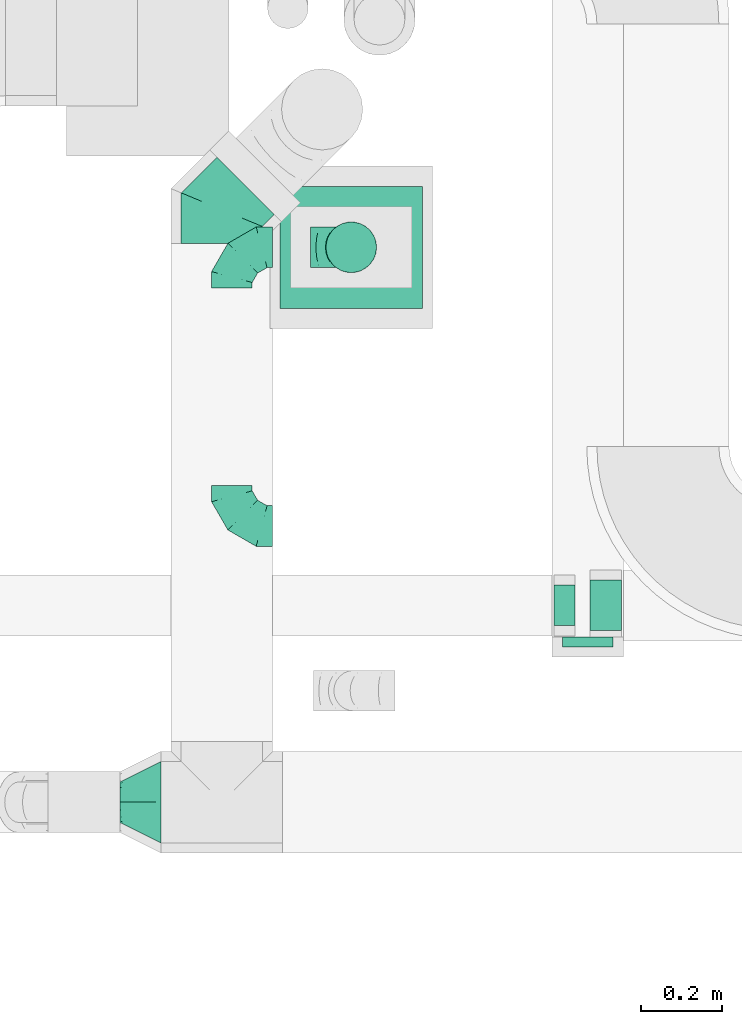
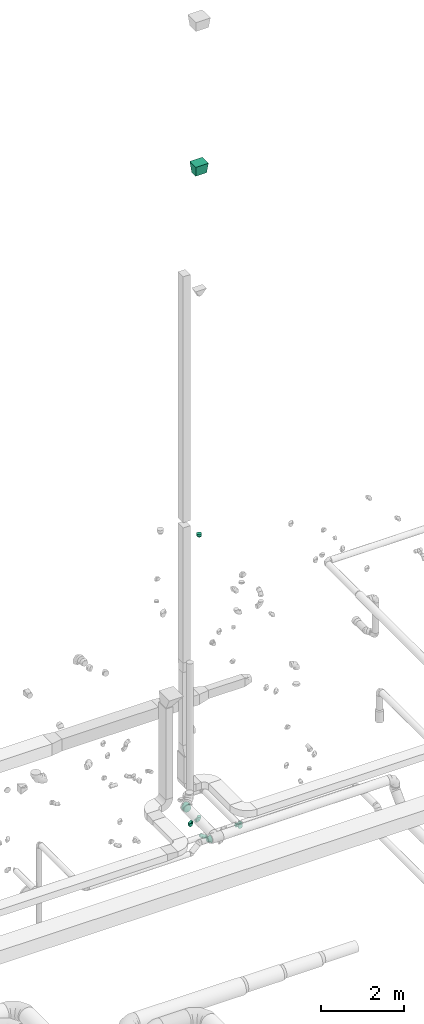
# One storey, part 65 of 97: 10 flow fittings, 1 flow segment.
"""IFC2X3 building model written with IfcOpenShell, lengths in millimetres."""

from ifc_helpers import new_model, entity, si_unit, converted_unit, derived_unit, direction, frame, origin, origin_2d_with_axis, place, context, subcontext, project, spatial, circle, extrude, faceted_brep, source, transform, mapped, material, type_object, type_shapes, element, save


model = new_model("IFC2X3")

# Units and contexts
model_context = context("Model", 3, precision=0.01, world=origin(), true_north=direction((6.12303176911189e-17, 1.0)))
body_context = subcontext(model_context, "Body", "Model", "MODEL_VIEW")
ifc_project = project(units=[si_unit("LENGTHUNIT", "METRE", prefix="MILLI"), si_unit("AREAUNIT", "SQUARE_METRE"), si_unit("VOLUMEUNIT", "CUBIC_METRE"), converted_unit("PLANEANGLEUNIT", "DEGREE", entity("IfcRatioMeasure", 0.0174532925199433), si_unit("PLANEANGLEUNIT", "RADIAN"), dimensions=[0, 0, 0, 0, 0, 0, 0]), si_unit("MASSUNIT", "GRAM", prefix="KILO"), derived_unit("MASSDENSITYUNIT", [(si_unit("MASSUNIT", "GRAM", prefix="KILO"), 1), (si_unit("LENGTHUNIT", "METRE"), -3)]), derived_unit("MOMENTOFINERTIAUNIT", [(si_unit("LENGTHUNIT", "METRE"), 4)]), si_unit("TIMEUNIT", "SECOND"), si_unit("FREQUENCYUNIT", "HERTZ"), si_unit("THERMODYNAMICTEMPERATUREUNIT", "DEGREE_CELSIUS"), derived_unit("THERMALTRANSMITTANCEUNIT", [(si_unit("MASSUNIT", "GRAM", prefix="KILO"), 1), (si_unit("THERMODYNAMICTEMPERATUREUNIT", "KELVIN"), -1), (si_unit("TIMEUNIT", "SECOND"), -3)]), derived_unit("VOLUMETRICFLOWRATEUNIT", [(si_unit("LENGTHUNIT", "METRE"), 3), (si_unit("TIMEUNIT", "SECOND"), -1)]), derived_unit("MASSFLOWRATEUNIT", [(si_unit("MASSUNIT", "GRAM", prefix="KILO"), 1), (si_unit("TIMEUNIT", "SECOND"), -1)]), derived_unit("ROTATIONALFREQUENCYUNIT", [(si_unit("TIMEUNIT", "SECOND"), -1)]), si_unit("ELECTRICCURRENTUNIT", "AMPERE"), si_unit("ELECTRICVOLTAGEUNIT", "VOLT"), si_unit("POWERUNIT", "WATT"), si_unit("FORCEUNIT", "NEWTON", prefix="KILO"), si_unit("ILLUMINANCEUNIT", "LUX"), si_unit("LUMINOUSFLUXUNIT", "LUMEN"), si_unit("LUMINOUSINTENSITYUNIT", "CANDELA"), derived_unit("USERDEFINED", [(si_unit("MASSUNIT", "GRAM", prefix="KILO"), -1), (si_unit("LENGTHUNIT", "METRE"), -2), (si_unit("TIMEUNIT", "SECOND"), 3), (si_unit("LUMINOUSFLUXUNIT", "LUMEN"), 1)]), derived_unit("LINEARVELOCITYUNIT", [(si_unit("LENGTHUNIT", "METRE"), 1), (si_unit("TIMEUNIT", "SECOND"), -1)]), si_unit("PRESSUREUNIT", "PASCAL"), derived_unit("USERDEFINED", [(si_unit("LENGTHUNIT", "METRE"), -2), (si_unit("MASSUNIT", "GRAM", prefix="KILO"), 1), (si_unit("TIMEUNIT", "SECOND"), -2)]), derived_unit("LINEARFORCEUNIT", [(si_unit("MASSUNIT", "GRAM", prefix="KILO"), 1), (si_unit("LENGTHUNIT", "METRE"), 1), (si_unit("TIMEUNIT", "SECOND"), -2), (si_unit("LENGTHUNIT", "METRE"), -1)]), derived_unit("PLANARFORCEUNIT", [(si_unit("MASSUNIT", "GRAM", prefix="KILO"), 1), (si_unit("LENGTHUNIT", "METRE"), 1), (si_unit("TIMEUNIT", "SECOND"), -2), (si_unit("LENGTHUNIT", "METRE"), -2)])], contexts=[model_context])

# Site, building, storey
site_placement = place(None, origin())
site = spatial("IfcSite", under=ifc_project, at=site_placement, CompositionType="ELEMENT")
building_placement = place(site_placement, origin())
building = spatial("IfcBuilding", under=site, at=building_placement, CompositionType="ELEMENT")
storey_placement = place(building_placement, frame((0.0, 0.0, -4900.0)))
storey = spatial("IfcBuildingStorey", under=building, at=storey_placement, CompositionType="ELEMENT", Elevation=-4900.0)

# Flow segment
duct_segment_type = type_object("IfcDuctSegmentType", PredefinedType="NOTDEFINED")
flow_segment_placement = place(storey_placement, frame((59416.46, 10900.54, 12290.0)))
element("IfcFlowSegment", 1, at=flow_segment_placement, inside=storey, type_object=duct_segment_type, context=body_context, shape_type="SweptSolid", body=[
    extrude(circle(Radius=62.5, at=origin_2d_with_axis()), frame((64.1, 64.1, 0.0)), (0.0, 0.0, 1.0), 59.9999999999723),
])

# Flow fittings
ifc_material = material()
duct_fitting_type_1 = type_object("IfcDuctFittingType", PredefinedType="NOTDEFINED", material=ifc_material)
shared_shape_1 = source(origin(), body_context, "Body", "SweptSolid", [
    extrude(circle(Radius=62.4999999999996, at=origin_2d_with_axis()), frame((0.0, 0.0, 0.0), z_axis=(1.0, 0.0, 0.0), x_axis=(0.0, 1.0, 0.0)), (0.0, 0.0, 1.0), 25.0000000000018),
])
type_shapes(duct_fitting_type_1, [shared_shape_1])
flow_fitting_1_placement = place(storey_placement, frame((60062.65, 10005.87, 4115.0), z_axis=(0.0, 0.0, 1.0), x_axis=(0.0, -1.0, 0.0)))
element("IfcFlowFitting", 2, at=flow_fitting_1_placement, inside=storey, type_object=duct_fitting_type_1, material=ifc_material, context=body_context, shape_type="MappedRepresentation", body=[
    mapped(shared_shape_1, transform((0.0, 0.0, 0.0), scale=1.0)),
])
duct_fitting_type_2 = type_object("IfcDuctFittingType", PredefinedType="NOTDEFINED", material=ifc_material)
shared_shape_2 = source(origin(), body_context, "Body", "Brep", [
    faceted_brep([(-100.0, 0.0, -50.0), (-100.0, -12.94, -48.3), (-100.0, -25.0, -43.3), (-100.0, -35.36, -35.36), (-100.0, -43.3, -25.0), (-100.0, -48.3, -12.94), (-100.0, -50.0, 0.0), (-100.0, -48.3, 12.94), (-100.0, -43.3, 25.0), (-100.0, -35.36, 35.36), (-100.0, -25.0, 43.3), (-100.0, -12.94, 48.3), (-100.0, 0.0, 50.0), (-100.0, 12.94, 48.3), (-100.0, 25.0, 43.3), (-100.0, 35.36, 35.36), (-100.0, 43.3, 25.0), (-100.0, 48.3, 12.94), (-100.0, 50.0, 0.0), (-100.0, 48.3, -12.94), (-100.0, 43.3, -25.0), (-100.0, 35.36, -35.36), (-100.0, 25.0, -43.3), (-100.0, 12.94, -48.3), (-76.67, 12.94, 48.3), (-79.9, 25.0, 43.3), (-73.21, 0.0, 50.0), (-82.68, 35.36, 35.36), (-86.15, 48.3, 12.94), (-86.6, 50.0, 0.0), (-84.81, 43.3, 25.0), (-84.81, 43.3, -25.0), (-82.68, 35.36, -35.36), (-86.15, 48.3, -12.94), (-76.67, 12.94, -48.3), (-73.21, 0.0, -50.0), (-79.9, 25.0, -43.3), (-69.74, -12.94, -48.3), (-66.51, -25.0, -43.3), (-63.73, -35.36, -35.36), (-61.6, -43.3, -25.0), (-60.26, -48.3, -12.94), (-59.81, -50.0, 0.0), (-60.26, -48.3, 12.94), (-61.6, -43.3, 25.0), (-63.73, -35.36, 35.36), (-66.51, -25.0, 43.3), (-69.74, -12.94, 48.3), (-36.27, 36.27, 48.3), (-45.1, 45.1, 43.3), (-26.79, 26.79, 50.0), (-52.68, 52.68, 35.36), (-58.49, 58.49, 25.0), (-62.15, 62.15, 12.94), (-63.4, 63.4, 0.0), (-62.15, 62.15, -12.94), (-58.49, 58.49, -25.0), (-52.68, 52.68, -35.36), (-36.27, 36.27, -48.3), (-26.79, 26.79, -50.0), (-45.1, 45.1, -43.3), (-17.32, 17.32, -48.3), (-8.49, 8.49, -43.3), (-0.91, 0.91, -35.36), (4.9, -4.9, -25.0), (8.56, -8.56, -12.94), (9.81, -9.81, 0.0), (8.56, -8.56, 12.94), (4.9, -4.9, 25.0), (-0.91, 0.91, 35.36), (-8.49, 8.49, 43.3), (-17.32, 17.32, 48.3), (-12.94, 76.67, 48.3), (-25.0, 79.9, 43.3), (0.0, 73.21, 50.0), (-35.36, 82.68, 35.36), (-43.3, 84.81, 25.0), (-48.3, 86.15, 12.94), (-50.0, 86.6, 0.0), (-48.3, 86.15, -12.94), (-43.3, 84.81, -25.0), (-35.36, 82.68, -35.36), (-12.94, 76.67, -48.3), (0.0, 73.21, -50.0), (-25.0, 79.9, -43.3), (12.94, 69.74, -48.3), (25.0, 66.51, -43.3), (35.36, 63.73, -35.36), (43.3, 61.6, -25.0), (48.3, 60.26, -12.94), (50.0, 59.81, 0.0), (48.3, 60.26, 12.94), (43.3, 61.6, 25.0), (35.36, 63.73, 35.36), (25.0, 66.51, 43.3), (12.94, 69.74, 48.3), (-12.94, 100.0, -48.3), (-25.0, 100.0, -43.3), (-35.36, 100.0, -35.36), (-43.3, 100.0, -25.0), (-48.3, 100.0, -12.94), (-50.0, 100.0, 0.0), (-48.3, 100.0, 12.94), (-43.3, 100.0, 25.0), (-35.36, 100.0, 35.36), (-25.0, 100.0, 43.3), (-12.94, 100.0, 48.3), (0.0, 100.0, 50.0), (12.94, 100.0, 48.3), (25.0, 100.0, 43.3), (35.36, 100.0, 35.36), (43.3, 100.0, 25.0), (48.3, 100.0, 12.94), (50.0, 100.0, 0.0), (48.3, 100.0, -12.94), (43.3, 100.0, -25.0), (35.36, 100.0, -35.36), (25.0, 100.0, -43.3), (12.94, 100.0, -48.3), (0.0, 100.0, -50.0)], [[[0, 1, 2, 3, 4, 5, 6, 7, 8, 9, 10, 11, 12, 13, 14, 15, 16, 17, 18, 19, 20, 21, 22, 23]], [[24, 25, 14, 13]], [[26, 24, 13, 12]], [[14, 25, 27, 15]], [[28, 29, 18, 17]], [[30, 28, 17, 16]], [[15, 27, 30, 16]], [[20, 31, 32, 21]], [[33, 31, 20, 19]], [[18, 29, 33, 19]], [[34, 35, 0, 23]], [[36, 34, 23, 22]], [[32, 36, 22, 21]], [[2, 1, 37, 38]], [[3, 2, 38, 39]], [[0, 35, 37, 1]], [[5, 4, 40, 41]], [[6, 5, 41, 42]], [[3, 39, 40, 4]], [[6, 42, 43, 7]], [[7, 43, 44, 8]], [[8, 44, 45, 9]], [[10, 46, 47, 11]], [[11, 47, 26, 12]], [[10, 9, 45, 46]], [[48, 49, 25, 24]], [[50, 48, 24, 26]], [[27, 25, 49, 51]], [[52, 53, 28, 30]], [[51, 52, 30, 27]], [[29, 28, 53, 54]], [[55, 56, 31, 33]], [[54, 55, 33, 29]], [[57, 32, 31, 56]], [[58, 59, 35, 34]], [[60, 58, 34, 36]], [[57, 60, 36, 32]], [[37, 35, 59, 61]], [[38, 37, 61, 62]], [[39, 38, 62, 63]], [[41, 40, 64, 65]], [[42, 41, 65, 66]], [[63, 64, 40, 39]], [[43, 42, 66, 67]], [[44, 43, 67, 68]], [[68, 69, 45, 44]], [[46, 45, 69, 70]], [[47, 46, 70, 71]], [[26, 47, 71, 50]], [[72, 73, 49, 48]], [[74, 72, 48, 50]], [[51, 49, 73, 75]], [[76, 77, 53, 52]], [[75, 76, 52, 51]], [[54, 53, 77, 78]], [[79, 80, 56, 55]], [[78, 79, 55, 54]], [[81, 57, 56, 80]], [[82, 83, 59, 58]], [[84, 82, 58, 60]], [[81, 84, 60, 57]], [[61, 59, 83, 85]], [[62, 61, 85, 86]], [[63, 62, 86, 87]], [[65, 64, 88, 89]], [[66, 65, 89, 90]], [[87, 88, 64, 63]], [[67, 66, 90, 91]], [[68, 67, 91, 92]], [[92, 93, 69, 68]], [[70, 69, 93, 94]], [[71, 70, 94, 95]], [[50, 71, 95, 74]], [[96, 97, 98, 99, 100, 101, 102, 103, 104, 105, 106, 107, 108, 109, 110, 111, 112, 113, 114, 115, 116, 117, 118, 119]], [[72, 74, 107, 106]], [[73, 72, 106, 105]], [[75, 73, 105, 104]], [[77, 76, 103, 102]], [[78, 77, 102, 101]], [[75, 104, 103, 76]], [[78, 101, 100, 79]], [[79, 100, 99, 80]], [[80, 99, 98, 81]], [[96, 119, 83, 82]], [[97, 96, 82, 84]], [[84, 81, 98, 97]], [[83, 119, 118, 85]], [[85, 118, 117, 86]], [[86, 117, 116, 87]], [[88, 115, 114, 89]], [[89, 114, 113, 90]], [[87, 116, 115, 88]], [[91, 90, 113, 112]], [[92, 91, 112, 111]], [[93, 92, 111, 110]], [[95, 94, 109, 108]], [[74, 95, 108, 107]], [[110, 109, 94, 93]]]),
])
type_shapes(duct_fitting_type_2, [shared_shape_2])
for number, where, z_axis, x_axis in (
    (3, (59186.81, 10964.63, 3925.0), (0.0, 0.0, 1.0), (-1.0, 0.0, 0.0)),
    (4, (59186.81, 10278.7, 3925.0), (0.0, 0.0, 1.0), (0.0, -1.0, 0.0)),
    (5, (59480.56, 10964.63, 3925.0), (0.0, -1.0, 0.0), (1.0, 0.0, 0.0)),
):
    element("IfcFlowFitting", number, at=place(storey_placement, frame(where, z_axis=z_axis, x_axis=x_axis)), inside=storey, type_object=duct_fitting_type_2, material=ifc_material, context=body_context, shape_type="MappedRepresentation", body=[
        mapped(shared_shape_2, transform((0.0, 0.0, 0.0), scale=1.0)),
    ])
duct_fitting_type_3 = type_object("IfcDuctFittingType", PredefinedType="NOTDEFINED", material=ifc_material)
shared_shape_3 = source(origin(), body_context, "Body", "Brep", [
    faceted_brep([(-82.84, 0.0, -100.0), (-82.84, -25.88, -96.59), (-82.84, -50.0, -86.6), (-82.84, -70.71, -70.71), (-82.84, -86.6, -50.0), (-82.84, -96.59, -25.88), (-82.84, -100.0, 0.0), (-82.84, -96.59, 25.88), (-82.84, -86.6, 50.0), (-82.84, -70.71, 70.71), (-82.84, -50.0, 86.6), (-82.84, -25.88, 96.59), (-82.84, 0.0, 100.0), (-82.84, 25.88, 96.59), (-82.84, 50.0, 86.6), (-82.84, 70.71, 70.71), (-82.84, 86.6, 50.0), (-82.84, 96.59, 25.88), (-82.84, 100.0, 0.0), (-82.84, 96.59, -25.88), (-82.84, 86.6, -50.0), (-82.84, 70.71, -70.71), (-82.84, 50.0, -86.6), (-82.84, 25.88, -96.59), (-10.72, 25.88, 96.59), (-20.71, 50.0, 86.6), (0.0, 0.0, 100.0), (-29.29, 70.71, 70.71), (-35.87, 86.6, 50.0), (-40.01, 96.59, 25.88), (-41.42, 100.0, 0.0), (-40.01, 96.59, -25.88), (-35.87, 86.6, -50.0), (-29.29, 70.71, -70.71), (-10.72, 25.88, -96.59), (0.0, 0.0, -100.0), (-20.71, 50.0, -86.6), (10.72, -25.88, -96.59), (20.71, -50.0, -86.6), (29.29, -70.71, -70.71), (35.87, -86.6, -50.0), (40.01, -96.59, -25.88), (41.42, -100.0, 0.0), (40.01, -96.59, 25.88), (35.87, -86.6, 50.0), (29.29, -70.71, 70.71), (20.71, -50.0, 86.6), (10.72, -25.88, 96.59), (58.58, 58.58, 100.0), (40.28, 76.88, 96.59), (23.22, 93.93, 86.6), (8.58, 108.58, 70.71), (-2.66, 119.82, 50.0), (-9.72, 126.88, 25.88), (-12.13, 129.29, 0.0), (-9.72, 126.88, -25.88), (-2.66, 119.82, -50.0), (8.58, 108.58, -70.71), (23.22, 93.93, -86.6), (40.28, 76.88, -96.59), (58.58, 58.58, -100.0), (76.88, 40.28, -96.59), (93.93, 23.22, -86.6), (108.58, 8.58, -70.71), (119.82, -2.66, -50.0), (126.88, -9.72, -25.88), (129.29, -12.13, 0.0), (126.88, -9.72, 25.88), (119.82, -2.66, 50.0), (108.58, 8.58, 70.71), (93.93, 23.22, 86.6), (76.88, 40.28, 96.59)], [[[0, 1, 2, 3, 4, 5, 6, 7, 8, 9, 10, 11, 12, 13, 14, 15, 16, 17, 18, 19, 20, 21, 22, 23]], [[24, 25, 14, 13]], [[26, 24, 13, 12]], [[14, 25, 27, 15]], [[28, 29, 17, 16]], [[28, 16, 15, 27]], [[30, 18, 17, 29]], [[31, 32, 20, 19]], [[30, 31, 19, 18]], [[32, 33, 21, 20]], [[34, 35, 0, 23]], [[36, 34, 23, 22]], [[33, 36, 22, 21]], [[1, 0, 35, 37]], [[2, 1, 37, 38]], [[38, 39, 3, 2]], [[5, 4, 40, 41]], [[6, 5, 41, 42]], [[39, 40, 4, 3]], [[6, 42, 43, 7]], [[7, 43, 44, 8]], [[8, 44, 45, 9]], [[9, 45, 46, 10]], [[10, 46, 47, 11]], [[26, 12, 11, 47]], [[24, 26, 48, 49]], [[25, 24, 49, 50]], [[27, 25, 50, 51]], [[29, 28, 52, 53]], [[30, 29, 53, 54]], [[51, 52, 28, 27]], [[30, 54, 55, 31]], [[31, 55, 56, 32]], [[57, 33, 32, 56]], [[36, 58, 59, 34]], [[34, 59, 60, 35]], [[58, 36, 33, 57]], [[35, 60, 61, 37]], [[37, 61, 62, 38]], [[63, 39, 38, 62]], [[40, 64, 65, 41]], [[41, 65, 66, 42]], [[64, 40, 39, 63]], [[43, 42, 66, 67]], [[44, 43, 67, 68]], [[68, 69, 45, 44]], [[47, 46, 70, 71]], [[26, 47, 71, 48]], [[69, 70, 46, 45]], [[59, 58, 57, 56, 55, 54, 53, 52, 51, 50, 49, 48, 71, 70, 69, 68, 67, 66, 65, 64, 63, 62, 61, 60]]]),
])
type_shapes(duct_fitting_type_3, [shared_shape_3])
flow_fitting_2_placement = place(storey_placement, frame((59162.01, 11057.25, 4350.0), z_axis=(0.0, 0.0, 1.0), x_axis=(-0.707106781186531, -0.707106781186564, 0.0)))
element("IfcFlowFitting", 6, at=flow_fitting_2_placement, inside=storey, type_object=duct_fitting_type_3, material=ifc_material, context=body_context, shape_type="MappedRepresentation", body=[
    mapped(shared_shape_3, transform((0.0, 0.0, 0.0), scale=1.0)),
])
duct_fitting_type_4 = type_object("IfcDuctFittingType", PredefinedType="NOTDEFINED", material=ifc_material)
shared_shape_4 = source(origin(), body_context, "Body", "Brep", [
    faceted_brep([(20.0, 12.94, -48.3), (20.0, 25.0, -43.3), (20.0, 35.36, -35.36), (20.0, 43.3, -25.0), (20.0, 48.3, -12.94), (20.0, 50.0, 0.0), (20.0, 48.3, 12.94), (20.0, 43.3, 25.0), (20.0, 35.36, 35.36), (20.0, 25.0, 43.3), (20.0, 12.94, 48.3), (20.0, 0.0, 50.0), (20.0, -12.94, 48.3), (20.0, -25.0, 43.3), (20.0, -35.36, 35.36), (20.0, -43.3, 25.0), (20.0, -48.3, 12.94), (20.0, -50.0, 0.0), (20.0, -48.3, -12.94), (20.0, -43.3, -25.0), (20.0, -35.36, -35.36), (20.0, -25.0, -43.3), (20.0, -12.94, -48.3), (20.0, 0.0, -50.0), (0.0, 0.0, 50.0), (0.0, 12.94, 48.3), (-31.1, 12.94, 48.3), (-31.1, 0.0, 50.0), (0.0, 25.0, 43.3), (-31.1, 25.0, 43.3), (0.0, 35.36, 35.36), (-31.1, 35.36, 35.36), (0.0, 43.3, 25.0), (0.0, 48.3, 12.94), (-31.1, 48.3, 12.94), (-31.1, 43.3, 25.0), (0.0, 50.0, 0.0), (-31.1, 50.0, 0.0), (0.0, 48.3, -12.94), (-31.1, 48.3, -12.94), (0.0, 43.3, -25.0), (-31.1, 43.3, -25.0), (0.0, 35.36, -35.36), (-31.1, 35.36, -35.36), (0.0, 25.0, -43.3), (0.0, 12.94, -48.3), (-31.1, 12.94, -48.3), (-31.1, 25.0, -43.3), (0.0, 0.0, -50.0), (-31.1, 0.0, -50.0), (0.0, -12.94, -48.3), (-31.1, -12.94, -48.3), (0.0, -25.0, -43.3), (-31.1, -25.0, -43.3), (0.0, -35.36, -35.36), (-31.1, -35.36, -35.36), (0.0, -43.3, -25.0), (0.0, -48.3, -12.94), (-31.1, -48.3, -12.94), (-31.1, -43.3, -25.0), (0.0, -50.0, 0.0), (-31.1, -50.0, 0.0), (0.0, -48.3, 12.94), (-31.1, -48.3, 12.94), (0.0, -43.3, 25.0), (-31.1, -43.3, 25.0), (0.0, -35.36, 35.36), (-31.1, -35.36, 35.36), (0.0, -25.0, 43.3), (0.0, -12.94, 48.3), (-31.1, -12.94, 48.3), (-31.1, -25.0, 43.3)], [[[0, 1, 2, 3, 4, 5, 6, 7, 8, 9, 10, 11, 12, 13, 14, 15, 16, 17, 18, 19, 20, 21, 22, 23]], [[24, 11, 10, 25, 26, 27]], [[25, 10, 9, 28, 29, 26]], [[28, 9, 8, 30, 31, 29]], [[32, 7, 6, 33, 34, 35]], [[33, 6, 5, 36, 37, 34]], [[30, 8, 7, 32, 35, 31]], [[36, 5, 4, 38, 39, 37]], [[38, 4, 3, 40, 41, 39]], [[40, 3, 2, 42, 43, 41]], [[44, 1, 0, 45, 46, 47]], [[45, 0, 23, 48, 49, 46]], [[42, 2, 1, 44, 47, 43]], [[48, 23, 22, 50, 51, 49]], [[50, 22, 21, 52, 53, 51]], [[52, 21, 20, 54, 55, 53]], [[56, 19, 18, 57, 58, 59]], [[57, 18, 17, 60, 61, 58]], [[54, 20, 19, 56, 59, 55]], [[60, 17, 16, 62, 63, 61]], [[62, 16, 15, 64, 65, 63]], [[64, 15, 14, 66, 67, 65]], [[68, 13, 12, 69, 70, 71]], [[69, 12, 11, 24, 27, 70]], [[66, 14, 13, 68, 71, 67]], [[49, 51, 53, 55, 59, 58, 61, 63, 65, 67, 71, 70, 27, 26, 29, 31, 35, 34, 37, 39, 41, 43, 47, 46]]]),
])
type_shapes(duct_fitting_type_4, [shared_shape_4])
flow_fitting_3_placement = place(storey_placement, frame((60000.15, 10083.58, 4115.0), z_axis=(0.0, 0.0, -1.0), x_axis=(-1.0, 0.0, 0.0)))
element("IfcFlowFitting", 7, at=flow_fitting_3_placement, inside=storey, type_object=duct_fitting_type_4, material=ifc_material, context=body_context, shape_type="MappedRepresentation", body=[
    mapped(shared_shape_4, transform((0.0, 0.0, 0.0), scale=1.0)),
])
duct_fitting_type_5 = type_object("IfcDuctFittingType", PredefinedType="NOTDEFINED", material=ifc_material)
shared_shape_5 = source(origin(), body_context, "Body", "Brep", [
    faceted_brep([(25.0, 0.0, -62.5), (25.0, 12.45, -60.02), (25.0, 23.92, -57.74), (25.0, 34.06, -50.97), (25.0, 44.19, -44.19), (25.0, 50.97, -34.06), (25.0, 57.74, -23.92), (25.0, 60.02, -12.45), (25.0, 62.5, 0.0), (25.0, 60.02, 12.45), (25.0, 57.74, 23.92), (25.0, 50.97, 34.06), (25.0, 44.19, 44.19), (25.0, 34.06, 50.97), (25.0, 23.92, 57.74), (25.0, 12.45, 60.02), (25.0, 0.0, 62.5), (25.0, -12.45, 60.02), (25.0, -23.92, 57.74), (25.0, -34.06, 50.97), (25.0, -44.19, 44.19), (25.0, -50.97, 34.06), (25.0, -57.74, 23.92), (25.0, -60.02, 12.45), (25.0, -62.5, 0.0), (25.0, -60.02, -12.45), (25.0, -57.74, -23.92), (25.0, -50.97, -34.06), (25.0, -44.19, -44.19), (25.0, -34.06, -50.97), (25.0, -23.92, -57.74), (25.0, -12.45, -60.02), (0.0, -19.13, -46.19), (0.0, -27.24, -40.77), (0.0, -35.36, -35.36), (0.0, -40.77, -27.24), (0.0, -46.19, -19.13), (0.0, -48.1, -9.57), (0.0, -50.0, 0.0), (0.0, -48.1, 9.57), (0.0, -46.19, 19.13), (0.0, -40.77, 27.24), (0.0, -35.36, 35.36), (0.0, -27.24, 40.77), (0.0, -19.13, 46.19), (0.0, -9.57, 48.1), (0.0, 0.0, 50.0), (0.0, 9.57, 48.1), (0.0, 19.13, 46.19), (0.0, 27.24, 40.77), (0.0, 35.36, 35.36), (0.0, 40.77, 27.24), (0.0, 46.19, 19.13), (0.0, 48.1, 9.57), (0.0, 50.0, 0.0), (0.0, 48.1, -9.57), (0.0, 46.19, -19.13), (0.0, 40.77, -27.24), (0.0, 35.36, -35.36), (0.0, 27.24, -40.77), (0.0, 19.13, -46.19), (0.0, 9.57, -48.1), (0.0, 0.0, -50.0), (0.0, -9.57, -48.1)], [[[0, 1, 2, 3, 4, 5, 6, 7, 8, 9, 10, 11, 12, 13, 14, 15, 16, 17, 18, 19, 20, 21, 22, 23, 24, 25, 26, 27, 28, 29, 30, 31]], [[32, 33, 34, 35, 36, 37, 38, 39, 40, 41, 42, 43, 44, 45, 46, 47, 48, 49, 50, 51, 52, 53, 54, 55, 56, 57, 58, 59, 60, 61, 62, 63]], [[52, 10, 9, 8, 54, 53]], [[51, 50, 12, 11, 10, 52]], [[47, 46, 16, 15, 14, 48]], [[49, 48, 14, 13, 12, 50]], [[44, 18, 17, 16, 46, 45]], [[43, 42, 20, 19, 18, 44]], [[39, 38, 24, 23, 22, 40]], [[41, 40, 22, 21, 20, 42]], [[36, 26, 25, 24, 38, 37]], [[35, 34, 28, 27, 26, 36]], [[63, 62, 0, 31, 30, 32]], [[33, 32, 30, 29, 28, 34]], [[60, 2, 1, 0, 62, 61]], [[59, 58, 4, 3, 2, 60]], [[55, 54, 8, 7, 6, 56]], [[57, 56, 6, 5, 4, 58]]]),
])
type_shapes(duct_fitting_type_5, [shared_shape_5])
flow_fitting_4_placement = place(storey_placement, frame((59480.56, 10964.63, 12265.0), z_axis=(-1.0, 0.0, 0.0), x_axis=(0.0, 0.0, 1.0)))
element("IfcFlowFitting", 8, at=flow_fitting_4_placement, inside=storey, type_object=duct_fitting_type_5, material=ifc_material, context=body_context, shape_type="MappedRepresentation", body=[
    mapped(shared_shape_5, transform((0.0, 0.0, 0.0), scale=1.0)),
])
duct_fitting_type_6 = type_object("IfcDuctFittingType", PredefinedType="NOTDEFINED", material=ifc_material)
shared_shape_6 = source(origin(), body_context, "Body", "Brep", [
    faceted_brep([(100.0, -58.78, -80.9), (100.0, -30.9, -95.11), (100.0, 0.0, -100.0), (100.0, 30.9, -95.11), (100.0, 58.78, -80.9), (100.0, 80.9, -58.78), (100.0, 95.11, -30.9), (100.0, 100.0, 0.0), (100.0, 95.11, 30.9), (100.0, 80.9, 58.78), (100.0, 58.78, 80.9), (100.0, 30.9, 95.11), (100.0, 0.0, 100.0), (100.0, -30.9, 95.11), (100.0, -58.78, 80.9), (100.0, -80.9, 58.78), (100.0, -95.11, 30.9), (100.0, -100.0, 0.0), (100.0, -95.11, -30.9), (100.0, -80.9, -58.78), (0.0, -19.13, -46.19), (0.0, -27.24, -40.77), (0.0, -35.36, -35.36), (0.0, -40.77, -27.24), (0.0, -46.19, -19.13), (0.0, -48.1, -9.57), (0.0, -50.0, 0.0), (0.0, -48.1, 9.57), (0.0, -46.19, 19.13), (0.0, -40.77, 27.24), (0.0, -35.36, 35.36), (0.0, -27.24, 40.77), (0.0, -19.13, 46.19), (0.0, -9.57, 48.1), (0.0, 0.0, 50.0), (0.0, 9.57, 48.1), (0.0, 19.13, 46.19), (0.0, 27.24, 40.77), (0.0, 35.36, 35.36), (0.0, 40.77, 27.24), (0.0, 46.19, 19.13), (0.0, 48.1, 9.57), (0.0, 50.0, 0.0), (0.0, 48.1, -9.57), (0.0, 46.19, -19.13), (0.0, 40.77, -27.24), (0.0, 35.36, -35.36), (0.0, 27.24, -40.77), (0.0, 19.13, -46.19), (0.0, 9.57, -48.1), (0.0, 0.0, -50.0), (0.0, -9.57, -48.1)], [[[0, 1, 2, 3, 4, 5, 6, 7, 8, 9, 10, 11, 12, 13, 14, 15, 16, 17, 18, 19]], [[20, 21, 22, 23, 24, 25, 26, 27, 28, 29, 30, 31, 32, 33, 34, 35, 36, 37, 38, 39, 40, 41, 42, 43, 44, 45, 46, 47, 48, 49, 50, 51]], [[7, 41, 8]], [[41, 7, 42]], [[40, 9, 8]], [[11, 36, 35]], [[41, 40, 8]], [[9, 40, 39, 38]], [[10, 38, 37, 36]], [[12, 35, 34]], [[11, 10, 36]], [[12, 11, 35]], [[38, 10, 9]], [[12, 33, 13]], [[33, 12, 34]], [[32, 14, 13]], [[16, 28, 27]], [[33, 32, 13]], [[14, 32, 31, 30]], [[15, 30, 29, 28]], [[17, 27, 26]], [[16, 15, 28]], [[17, 16, 27]], [[30, 15, 14]], [[17, 25, 18]], [[25, 17, 26]], [[24, 19, 18]], [[1, 20, 51]], [[25, 24, 18]], [[19, 24, 23, 22]], [[0, 22, 21, 20]], [[2, 51, 50]], [[1, 0, 20]], [[2, 1, 51]], [[22, 0, 19]], [[2, 49, 3]], [[49, 2, 50]], [[48, 4, 3]], [[6, 44, 43]], [[49, 48, 3]], [[4, 48, 47, 46]], [[5, 46, 45, 44]], [[7, 43, 42]], [[6, 5, 44]], [[7, 6, 43]], [[46, 5, 4]]]),
])
type_shapes(duct_fitting_type_6, [shared_shape_6])
flow_fitting_5_placement = place(storey_placement, frame((58912.01, 9598.98, 4350.0)))
element("IfcFlowFitting", 9, at=flow_fitting_5_placement, inside=storey, type_object=duct_fitting_type_6, material=ifc_material, context=body_context, shape_type="MappedRepresentation", body=[
    mapped(shared_shape_6, transform((0.0, 0.0, 0.0), scale=1.0)),
])
duct_fitting_type_7 = type_object("IfcDuctFittingType", PredefinedType="NOTDEFINED", material=ifc_material)
shared_shape_7 = source(origin(), body_context, "Body", "Brep", [
    faceted_brep([(20.0, 0.0, -62.5), (20.0, 16.18, -60.37), (20.0, 31.25, -54.13), (20.0, 44.19, -44.19), (20.0, 54.13, -31.25), (20.0, 60.37, -16.18), (20.0, 62.5, 0.0), (20.0, 60.37, 16.18), (20.0, 54.13, 31.25), (20.0, 44.19, 44.19), (20.0, 31.25, 54.13), (20.0, 16.18, 60.37), (20.0, 0.0, 62.5), (20.0, -16.18, 60.37), (20.0, -31.25, 54.13), (20.0, -44.19, 44.19), (20.0, -54.13, 31.25), (20.0, -60.37, 16.18), (20.0, -62.5, 0.0), (20.0, -60.37, -16.18), (20.0, -54.13, -31.25), (20.0, -44.19, -44.19), (20.0, -31.25, -54.13), (20.0, -16.18, -60.37), (0.0, 0.0, 62.5), (-56.4, 0.0, 62.5), (-56.4, -16.18, 60.37), (0.0, -16.18, 60.37), (-56.4, -31.25, 54.13), (0.0, -31.25, 54.13), (0.0, -44.19, 44.19), (-56.4, -44.19, 44.19), (0.0, -54.13, 31.25), (-56.4, -54.13, 31.25), (-56.4, -60.37, 16.18), (0.0, -60.37, 16.18), (-56.4, -62.5, 0.0), (0.0, -62.5, 0.0), (-56.4, -60.37, -16.18), (0.0, -60.37, -16.18), (-56.4, -54.13, -31.25), (0.0, -54.13, -31.25), (0.0, -44.19, -44.19), (-56.4, -44.19, -44.19), (0.0, -31.25, -54.13), (-56.4, -31.25, -54.13), (-56.4, -16.18, -60.37), (0.0, -16.18, -60.37), (-56.4, 0.0, -62.5), (0.0, 0.0, -62.5), (-56.4, 16.18, -60.37), (0.0, 16.18, -60.37), (-56.4, 31.25, -54.13), (0.0, 31.25, -54.13), (0.0, 44.19, -44.19), (-56.4, 44.19, -44.19), (0.0, 54.13, -31.25), (-56.4, 54.13, -31.25), (-56.4, 60.37, -16.18), (0.0, 60.37, -16.18), (-56.4, 62.5, 0.0), (0.0, 62.5, 0.0), (-56.4, 60.37, 16.18), (0.0, 60.37, 16.18), (-56.4, 54.13, 31.25), (0.0, 54.13, 31.25), (0.0, 44.19, 44.19), (-56.4, 44.19, 44.19), (0.0, 31.25, 54.13), (-56.4, 31.25, 54.13), (-56.4, 16.18, 60.37), (0.0, 16.18, 60.37)], [[[0, 1, 2, 3, 4, 5, 6, 7, 8, 9, 10, 11, 12, 13, 14, 15, 16, 17, 18, 19, 20, 21, 22, 23]], [[13, 12, 24, 25, 26, 27]], [[14, 13, 27, 26, 28, 29]], [[30, 15, 14, 29, 28, 31]], [[17, 16, 32, 33, 34, 35]], [[18, 17, 35, 34, 36, 37]], [[32, 16, 15, 30, 31, 33]], [[19, 18, 37, 36, 38, 39]], [[20, 19, 39, 38, 40, 41]], [[42, 21, 20, 41, 40, 43]], [[23, 22, 44, 45, 46, 47]], [[0, 23, 47, 46, 48, 49]], [[44, 22, 21, 42, 43, 45]], [[1, 0, 49, 48, 50, 51]], [[2, 1, 51, 50, 52, 53]], [[54, 3, 2, 53, 52, 55]], [[5, 4, 56, 57, 58, 59]], [[6, 5, 59, 58, 60, 61]], [[56, 4, 3, 54, 55, 57]], [[7, 6, 61, 60, 62, 63]], [[8, 7, 63, 62, 64, 65]], [[66, 9, 8, 65, 64, 67]], [[11, 10, 68, 69, 70, 71]], [[12, 11, 71, 70, 25, 24]], [[68, 10, 9, 66, 67, 69]], [[46, 45, 43, 40, 38, 36, 34, 33, 31, 28, 26, 25, 70, 69, 67, 64, 62, 60, 58, 57, 55, 52, 50, 48]]]),
])
type_shapes(duct_fitting_type_7, [shared_shape_7])
flow_fitting_6_placement = place(storey_placement, frame((60125.15, 10083.58, 4115.0), z_axis=(0.0, 0.0, -1.0), x_axis=(1.0, 0.0, 0.0)))
element("IfcFlowFitting", 10, at=flow_fitting_6_placement, inside=storey, type_object=duct_fitting_type_7, material=ifc_material, context=body_context, shape_type="MappedRepresentation", body=[
    mapped(shared_shape_7, transform((0.0, 0.0, 0.0), scale=1.0)),
])
duct_fitting_type_8 = type_object("IfcDuctFittingType", PredefinedType="NOTDEFINED", material=ifc_material)
shared_shape_8 = source(origin(), body_context, "Body", "Brep", [
    faceted_brep([(300.0, -175.0, 150.0), (300.0, -175.0, -150.0), (300.0, 175.0, -150.0), (300.0, 175.0, 150.0), (0.0, -150.0, 100.0), (0.0, 150.0, 100.0), (0.0, 150.0, -100.0), (0.0, -150.0, -100.0)], [[[0, 1, 2, 3]], [[4, 5, 6, 7]], [[4, 7, 1, 0]], [[7, 6, 2, 1]], [[6, 5, 3, 2]], [[5, 4, 0, 3]]]),
])
type_shapes(duct_fitting_type_8, [shared_shape_8])
flow_fitting_7_placement = place(storey_placement, frame((59480.56, 10964.63, 22965.0), z_axis=(0.0, -1.0, 0.0), x_axis=(0.0, 0.0, 1.0)))
element("IfcFlowFitting", 11, at=flow_fitting_7_placement, inside=storey, type_object=duct_fitting_type_8, material=ifc_material, context=body_context, shape_type="MappedRepresentation", body=[
    mapped(shared_shape_8, transform((0.0, 0.0, 0.0), scale=1.0)),
])

save(model, "model.ifc")
